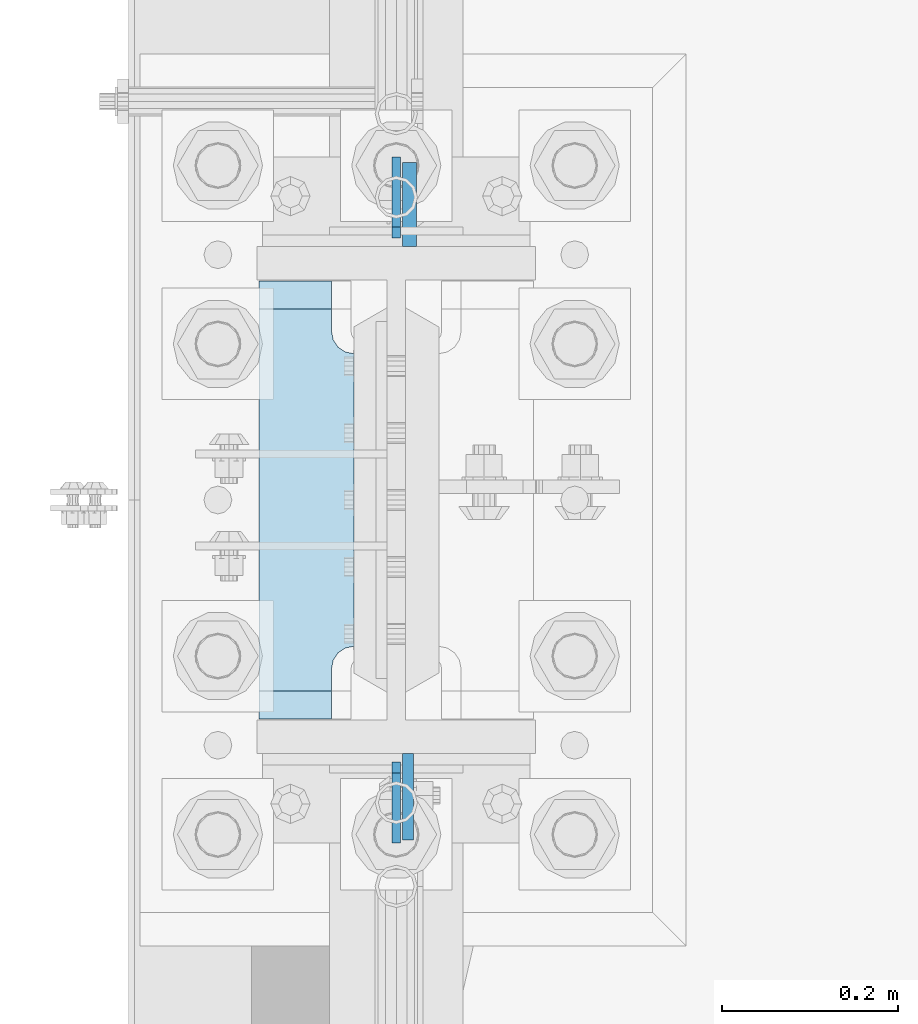
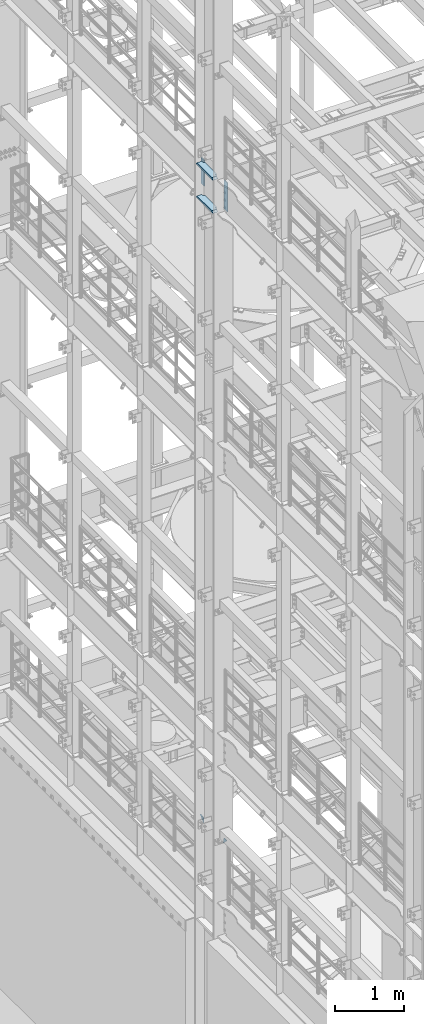
# One storey, part 1690 of 1876: 6 plates, 2 elements without a shape of their own.
"""IFC2X3 building model written with IfcOpenShell, lengths in millimetres."""

from ifc_helpers import new_model, si_unit, frame, origin_with_axes, place, context, subcontext, project, spatial, faceted_brep, material, type_object, element, aggregate, save


model = new_model("IFC2X3")

# Units and contexts
model_context = context("Model", 3, precision=1e-05, world=origin_with_axes())
body_context = subcontext(model_context, "Body", "Model", "MODEL_VIEW")
ifc_project = project(units=[si_unit("LENGTHUNIT", "METRE", prefix="MILLI"), si_unit("AREAUNIT", "SQUARE_METRE"), si_unit("VOLUMEUNIT", "CUBIC_METRE"), si_unit("MASSUNIT", "GRAM", prefix="KILO"), si_unit("TIMEUNIT", "SECOND"), si_unit("PLANEANGLEUNIT", "RADIAN"), si_unit("SOLIDANGLEUNIT", "STERADIAN"), si_unit("THERMODYNAMICTEMPERATUREUNIT", "DEGREE_CELSIUS"), si_unit("LUMINOUSINTENSITYUNIT", "LUMEN")], contexts=[model_context])

# Site, building, storey
site_placement = place(None, origin_with_axes())
site = spatial("IfcSite", under=ifc_project, at=site_placement, CompositionType="ELEMENT")
building_placement = place(site_placement, origin_with_axes())
building = spatial("IfcBuilding", under=site, at=building_placement, Name="Undefined", CompositionType="ELEMENT")
storey_placement = place(building_placement, origin_with_axes())
storey = spatial("IfcBuildingStorey", under=building, at=storey_placement, Name="Undefined", CompositionType="ELEMENT", Elevation=0.0)

# Assembly, plates
assembly_1_placement = place(storey_placement, origin_with_axes())
assembly_1 = element("IfcElementAssembly", 1, at=assembly_1_placement, inside=storey, Name="COLUMN", AssemblyPlace="NOTDEFINED", PredefinedType="RIGID_FRAME")
ifc_material_1 = material(Name="STEEL/A36")
plate_type_1 = type_object("IfcPlateType", PredefinedType="NOTDEFINED")
plate_1_placement = place(assembly_1_placement, frame((0.0, 8010.52500059683, 6235.7), z_axis=(0.0, -0.707106781186548, 0.707106781186548), x_axis=(0.0, -0.707106781186548, -0.707106781186548)))
plate_1 = element("IfcPlate", 2, at=plate_1_placement, type_object=plate_type_1, material=ifc_material_1, Name="PLATE", context=body_context, shape_type="Brep", body=[
    faceted_brep([(0.0, -4.76249999999982, 0.0), (56.1266013136901, -4.76249999997708, 56.1266013135391), (56.1266013136883, 4.76250000002256, 56.1266013135428), (0.0, 4.76249999999982, 0.0), (74.0871132860975, -4.7624999999698, 56.1266013135246), (74.0871132860993, 4.76250000002983, 56.1266013135282), (130.213714599717, -4.76249999994707, -1.30967237055302e-10), (130.213714599715, 4.76250000005257, -1.23691279441118e-10)], [[[0, 1, 2, 3]], [[1, 4, 5, 2]], [[4, 6, 7, 5]], [[6, 0, 3, 7]], [[5, 7, 3, 2]], [[6, 4, 1, 0]]]),
])
plate_2_placement = place(assembly_1_placement, frame((0.0, 7229.47499940317, 6235.7), z_axis=(0.0, 0.707106781186548, 0.707106781186548), x_axis=(0.0, 0.707106781186548, -0.707106781186548)))
plate_2 = element("IfcPlate", 3, at=plate_2_placement, type_object=plate_type_1, material=ifc_material_1, Name="PLATE", context=body_context, shape_type="Brep", body=[
    faceted_brep([(0.0, -4.76249999999982, 0.0), (56.1266013136901, -4.76249999997708, 56.1266013135391), (56.1266013136883, 4.76250000002256, 56.1266013135428), (0.0, 4.76249999999982, 0.0), (74.0871132860975, -4.7624999999698, 56.1266013135246), (74.0871132860993, 4.76250000002983, 56.1266013135282), (130.213714599717, -4.76249999994707, -1.30967237055302e-10), (130.213714599715, 4.76250000005257, -1.23691279441118e-10)], [[[0, 1, 2, 3]], [[1, 4, 5, 2]], [[4, 6, 7, 5]], [[6, 0, 3, 7]], [[5, 7, 3, 2]], [[6, 4, 1, 0]]]),
])
aggregate(assembly_1, [plate_1, plate_2])

assembly_2_placement = place(storey_placement, origin_with_axes())
assembly_2 = element("IfcElementAssembly", 4, at=assembly_2_placement, inside=storey, Name="COLUMN", AssemblyPlace="NOTDEFINED", PredefinedType="RIGID_FRAME")
ifc_material_2 = material(Name="STEEL/A572-50")
plate_type_2 = type_object("IfcPlateType", PredefinedType="NOTDEFINED")
plate_3_placement = place(assembly_2_placement, frame((13.493000125885, 7331.075, 17929.225), z_axis=(0.0, -1.0, 0.0), x_axis=(0.0, 0.0, -1.0)))
plate_3 = element("IfcPlate", 5, at=plate_3_placement, type_object=plate_type_2, material=ifc_material_2, Name="PLATE", context=body_context, shape_type="Brep", body=[
    faceted_brep([(0.0, -6.35000000000036, 0.0), (0.0, -6.34999999999991, 98.4250030517578), (0.0, 6.34999999999991, 98.4250030517578), (0.0, 6.35000000000036, 0.0), (514.349975585938, -6.35000000000036, 98.4250030517578), (514.349975585938, 6.35000000000036, 98.4250030517578), (514.349975585938, -6.35000000000036, 0.0), (514.349975585938, 6.35000000000036, 0.0)], [[[0, 1, 2, 3]], [[1, 4, 5, 2]], [[4, 6, 7, 5]], [[6, 0, 3, 7]], [[5, 7, 3, 2]], [[6, 4, 1, 0]]]),
])
plate_type_3 = type_object("IfcPlateType", PredefinedType="NOTDEFINED")
plate_4_placement = place(assembly_2_placement, frame((15.080500125885, 7908.925, 17919.7), z_axis=(0.0, 1.0, 0.0), x_axis=(0.0, 0.0, -1.0)))
plate_4 = element("IfcPlate", 6, at=plate_4_placement, type_object=plate_type_3, material=ifc_material_2, Name="PLATE", context=body_context, shape_type="Brep", body=[
    faceted_brep([(0.0, -7.9375, 0.0), (0.0, -7.9375, 95.25), (0.0, 7.9375, 95.25), (0.0, 7.9375, 0.0), (457.200012207031, -7.9375, 95.25), (457.200012207031, 7.9375, 95.25), (457.200012207031, -7.9375, 0.0), (457.200012207031, 7.9375, 0.0)], [[[0, 1, 2, 3]], [[1, 4, 5, 2]], [[4, 6, 7, 5]], [[6, 0, 3, 7]], [[5, 7, 3, 2]], [[6, 4, 1, 0]]]),
])
plate_type_4 = type_object("IfcPlateType", PredefinedType="NOTDEFINED")
plate_5_placement = place(assembly_2_placement, frame((-48.41875, 7370.7625, 17376.775012207), z_axis=(0.0, 1.0, 0.0), x_axis=(-1.0, 0.0, 0.0)))
plate_5 = element("IfcPlate", 7, at=plate_5_placement, type_object=plate_type_4, material=ifc_material_2, Name="PLATE", context=body_context, shape_type="Brep", body=[
    faceted_brep([(107.949996948242, -15.875, 498.475006103516), (107.949996948242, 15.875, 467.025007631571), (25.3999996185303, 15.875, 467.025007631571), (25.3999996185303, -15.875, 498.475006103516), (23.4665397733561, -15.875, 431.604843634198), (25.3999996185303, -15.875, 441.325002670288), (25.3999996185303, 15.875, 441.325002670288), (23.4665397733561, 15.875, 431.604843634198), (17.9605119724001, -15.875, 423.36449069789), (17.9605119724001, 15.875, 423.36449069789), (9.72015903609281, -15.875, 417.858462896934), (9.72015903609281, 15.875, 417.858462896934), (0.0, -15.875, 415.925003051758), (0.0, 15.875, 415.925003051758), (0.0, -15.875, 82.5500030517578), (0.0, 15.875, 82.5500030517578), (9.72015903609099, -15.875, 80.616543206582), (9.72015903609099, 15.875, 80.616543206582), (17.9605119723983, -15.875, 75.1105154056258), (17.9605119723983, 15.875, 75.1105154056258), (23.4665397733552, -15.875, 66.8701624693183), (23.4665397733552, 15.875, 66.8701624693183), (25.3999996185303, -15.875, 57.1500034332275), (25.3999996185303, 15.875, 57.1500034332275), (25.3999996185303, 15.875, 31.449998471945), (25.3999996185303, -15.875, 0.0), (107.949996948242, 15.875, 31.449998471945), (107.949996948242, -15.875, 0.0)], [[[0, 1, 2, 3]], [[4, 5, 6, 7]], [[8, 4, 7, 9]], [[10, 8, 9, 11]], [[12, 10, 11, 13]], [[14, 12, 13, 15]], [[16, 14, 15, 17]], [[18, 16, 17, 19]], [[20, 18, 19, 21]], [[22, 20, 21, 23]], [[22, 23, 24, 25]], [[26, 27, 25, 24]], [[5, 4, 8, 10, 12, 14, 16, 18, 20, 22, 25, 27, 0, 3]], [[6, 5, 3, 2]], [[26, 24, 23, 21, 19, 17, 15, 13, 11, 9, 7, 6, 2, 1]], [[27, 26, 1, 0]]]),
])
plate_6_placement = place(assembly_2_placement, frame((-48.41875, 7370.7625, 17967.325), z_axis=(0.0, 1.0, 0.0), x_axis=(-1.0, 0.0, 0.0)))
plate_6 = element("IfcPlate", 8, at=plate_6_placement, type_object=plate_type_4, material=ifc_material_2, Name="PLATE", context=body_context, shape_type="Brep", body=[
    faceted_brep([(107.949996948242, -15.875, 498.475006103516), (107.949996948242, 15.875, 467.025007631571), (25.3999996185303, 15.875, 467.025007631571), (25.3999996185303, -15.875, 498.475006103516), (23.4665397733561, -15.875, 431.604843634198), (25.3999996185303, -15.875, 441.325002670288), (25.3999996185303, 15.875, 441.325002670288), (23.4665397733561, 15.875, 431.604843634198), (17.9605119724001, -15.875, 423.36449069789), (17.9605119724001, 15.875, 423.36449069789), (9.72015903609281, -15.875, 417.858462896934), (9.72015903609281, 15.875, 417.858462896934), (0.0, -15.875, 415.925003051758), (0.0, 15.875, 415.925003051758), (0.0, -15.875, 82.5500030517578), (0.0, 15.875, 82.5500030517578), (9.72015903609099, -15.875, 80.616543206582), (9.72015903609099, 15.875, 80.616543206582), (17.9605119723983, -15.875, 75.1105154056258), (17.9605119723983, 15.875, 75.1105154056258), (23.4665397733552, -15.875, 66.8701624693183), (23.4665397733552, 15.875, 66.8701624693183), (25.3999996185303, -15.875, 57.1500034332275), (25.3999996185303, 15.875, 57.1500034332275), (25.3999996185303, 15.875, 31.449998471945), (25.3999996185303, -15.875, 0.0), (107.949996948242, 15.875, 31.449998471945), (107.949996948242, -15.875, 0.0)], [[[0, 1, 2, 3]], [[4, 5, 6, 7]], [[8, 4, 7, 9]], [[10, 8, 9, 11]], [[12, 10, 11, 13]], [[14, 12, 13, 15]], [[16, 14, 15, 17]], [[18, 16, 17, 19]], [[20, 18, 19, 21]], [[22, 20, 21, 23]], [[22, 23, 24, 25]], [[26, 27, 25, 24]], [[5, 4, 8, 10, 12, 14, 16, 18, 20, 22, 25, 27, 0, 3]], [[6, 5, 3, 2]], [[26, 24, 23, 21, 19, 17, 15, 13, 11, 9, 7, 6, 2, 1]], [[27, 26, 1, 0]]]),
])
aggregate(assembly_2, [plate_3, plate_4, plate_5, plate_6])

save(model, "model.ifc")
